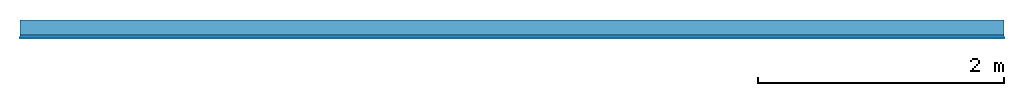
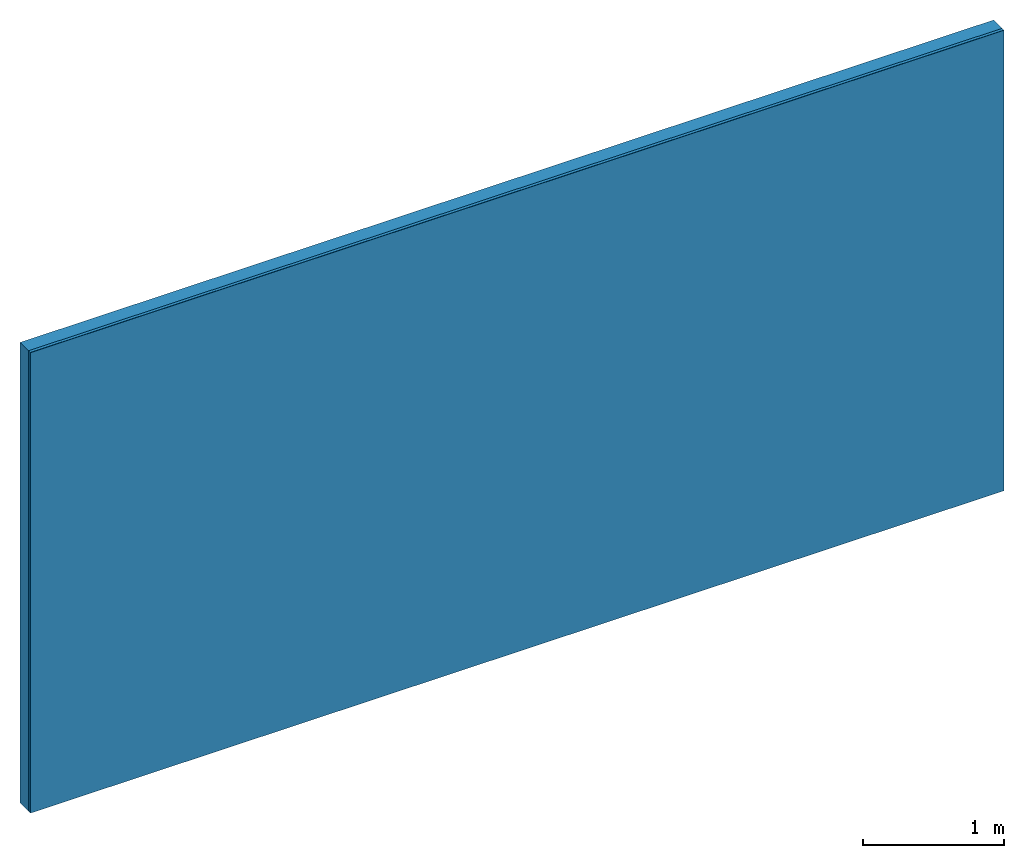
# One storey: 2 plates, 1 member, 1 element without a shape of its own.
"""IFC4 building model written with IfcOpenShell, lengths in metres."""

from ifc_helpers import new_model, si_unit, derived_unit, direction, frame, frame_2d, origin, place, context, project, spatial, rectangle, extrude, material, layer, layer_set, type_object, element, aggregate, save


model = new_model("IFC4")

# Units and contexts
plan_context = context("Plan", 3, precision=1e-05, world=origin(), true_north=direction((0.0, 1.0)))
model_context = context("Model", 3, precision=1e-05, world=origin(), true_north=direction((0.0, 1.0)))
ifc_project = project(units=[si_unit("LENGTHUNIT", "METRE"), derived_unit("SOUNDPRESSUREUNIT", [(si_unit("PRESSUREUNIT", "PASCAL", prefix="MICRO"), 0)]), si_unit("ENERGYUNIT", "JOULE", prefix="MEGA"), si_unit("MASSUNIT", "GRAM", prefix="KILO"), derived_unit("THERMALTRANSMITTANCEUNIT", [(si_unit("POWERUNIT", "WATT"), 1), (si_unit("AREAUNIT", "SQUARE_METRE"), -1), (si_unit("THERMODYNAMICTEMPERATUREUNIT", "KELVIN"), -1)]), derived_unit("AREADENSITYUNIT", [(si_unit("MASSUNIT", "GRAM", prefix="KILO"), 1), (si_unit("AREAUNIT", "SQUARE_METRE"), -1)]), derived_unit("USERDEFINED", [(si_unit("ENERGYUNIT", "JOULE", prefix="MEGA"), 1), (si_unit("AREAUNIT", "SQUARE_METRE"), -1)])], contexts=[plan_context, model_context])

# Site, building, storey
site = spatial("IfcSite", under=ifc_project)
building_placement = place(None, origin())
building = spatial("IfcBuilding", under=site, at=building_placement)
storey_placement = place(building_placement, origin())
storey = spatial("IfcBuildingStorey", under=building, at=storey_placement)

# Wall, member, plates
ifc_layer_1 = layer(None, 0.12, Name="Support")
ifc_material_1 = material(Name="of the art")
ifc_layer_2 = layer(ifc_material_1, 0.0, Name="Bond")
ifc_material_2 = material(Name="Clay panels")
ifc_layer_3 = layer(ifc_material_2, 0.025, Name="1st layer")
ifc_material_3 = material(Category="04.001")
ifc_layer_4 = layer(ifc_material_3, 0.003, Name="Surface")
ifc_layer_set = layer_set([ifc_layer_1, ifc_layer_2, ifc_layer_3, ifc_layer_4])
wall_type = type_object("IfcWallType", Name="C0357", PredefinedType="NOTDEFINED", material=ifc_layer_set)
wall_placement = place(None, frame((0.0, 0.0, 0.0), z_axis=(0.0, -1.0, 0.0), x_axis=(1.0, 0.0, 0.0)))
wall = element("IfcWall", 1, at=wall_placement, inside=storey, type_object=wall_type, material=ifc_layer_set, Name="Wall #1")
ifc_material_4 = material(Name="Solid timber panel")
member_placement = place(wall_placement, origin())
member = element("IfcMember", 2, at=member_placement, material=ifc_material_4, Name="Support", context=plan_context, shape_type="SweptSolid", body=[
    extrude(rectangle(XDim=1.0, YDim=0.12, at=frame_2d((0.5, 0.06), x_axis=(1.0, 0.0))), frame((0.0, 4.0, 0.0), z_axis=(0.0, -1.0, 0.0), x_axis=(1.0, 0.0, 0.0)), (0.0, 0.0, 1.0), 4.0),
    extrude(rectangle(XDim=1.0, YDim=0.12, at=frame_2d((0.5, 0.06), x_axis=(1.0, 0.0))), frame((1.0, 4.0, 0.0), z_axis=(0.0, -1.0, 0.0), x_axis=(1.0, 0.0, 0.0)), (0.0, 0.0, 1.0), 4.0),
    extrude(rectangle(XDim=1.0, YDim=0.12, at=frame_2d((0.5, 0.06), x_axis=(1.0, 0.0))), frame((2.0, 4.0, 0.0), z_axis=(0.0, -1.0, 0.0), x_axis=(1.0, 0.0, 0.0)), (0.0, 0.0, 1.0), 4.0),
    extrude(rectangle(XDim=1.0, YDim=0.12, at=frame_2d((0.5, 0.06), x_axis=(1.0, 0.0))), frame((3.0, 4.0, 0.0), z_axis=(0.0, -1.0, 0.0), x_axis=(1.0, 0.0, 0.0)), (0.0, 0.0, 1.0), 4.0),
    extrude(rectangle(XDim=1.0, YDim=0.12, at=frame_2d((0.5, 0.06), x_axis=(1.0, 0.0))), frame((4.0, 4.0, 0.0), z_axis=(0.0, -1.0, 0.0), x_axis=(1.0, 0.0, 0.0)), (0.0, 0.0, 1.0), 4.0),
    extrude(rectangle(XDim=1.0, YDim=0.12, at=frame_2d((0.5, 0.06), x_axis=(1.0, 0.0))), frame((5.0, 4.0, 0.0), z_axis=(0.0, -1.0, 0.0), x_axis=(1.0, 0.0, 0.0)), (0.0, 0.0, 1.0), 4.0),
    extrude(rectangle(XDim=1.0, YDim=0.12, at=frame_2d((0.5, 0.06), x_axis=(1.0, 0.0))), frame((6.0, 4.0, 0.0), z_axis=(0.0, -1.0, 0.0), x_axis=(1.0, 0.0, 0.0)), (0.0, 0.0, 1.0), 4.0),
    extrude(rectangle(XDim=1.0, YDim=0.12, at=frame_2d((0.5, 0.06), x_axis=(1.0, 0.0))), frame((7.0, 4.0, 0.0), z_axis=(0.0, -1.0, 0.0), x_axis=(1.0, 0.0, 0.0)), (0.0, 0.0, 1.0), 4.0),
])
plate_1_placement = place(wall_placement, origin())
plate_1 = element("IfcPlate", 3, at=plate_1_placement, material=ifc_material_2, Name="1st layer", context=plan_context, shape_type="SweptSolid", body=[
    extrude(rectangle(XDim=8.0, YDim=4.0, at=frame_2d((4.0, 2.0), x_axis=(1.0, 0.0))), frame((0.0, 0.0, 0.12), z_axis=(0.0, 0.0, 1.0), x_axis=(1.0, 0.0, 0.0)), (0.0, 0.0, 1.0), 0.025),
])
plate_2_placement = place(wall_placement, origin())
plate_2 = element("IfcPlate", 4, at=plate_2_placement, material=ifc_material_3, Name="Surface", context=plan_context, shape_type="SweptSolid", body=[
    extrude(rectangle(XDim=8.0, YDim=4.0, at=frame_2d((4.0, 2.0), x_axis=(1.0, 0.0))), frame((0.0, 0.0, 0.145), z_axis=(0.0, 0.0, 1.0), x_axis=(1.0, 0.0, 0.0)), (0.0, 0.0, 1.0), 0.003),
])
aggregate(wall, [member, plate_1, plate_2])

save(model, "model.ifc")
